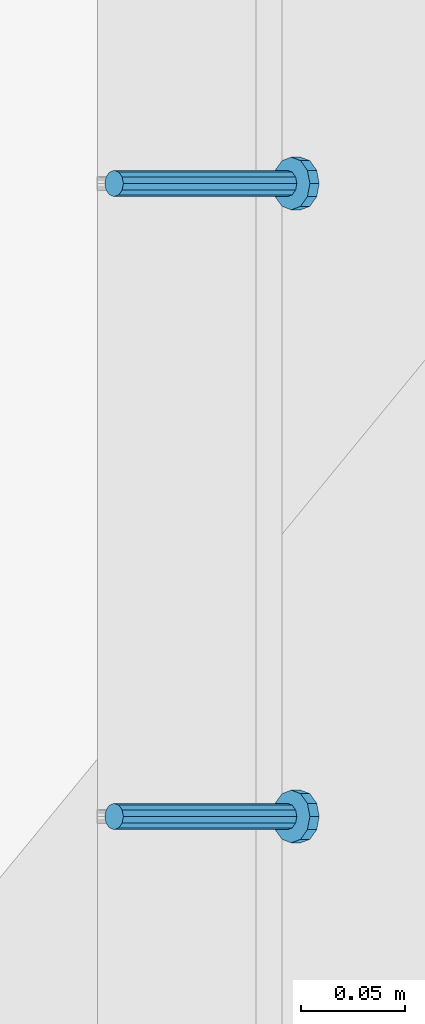
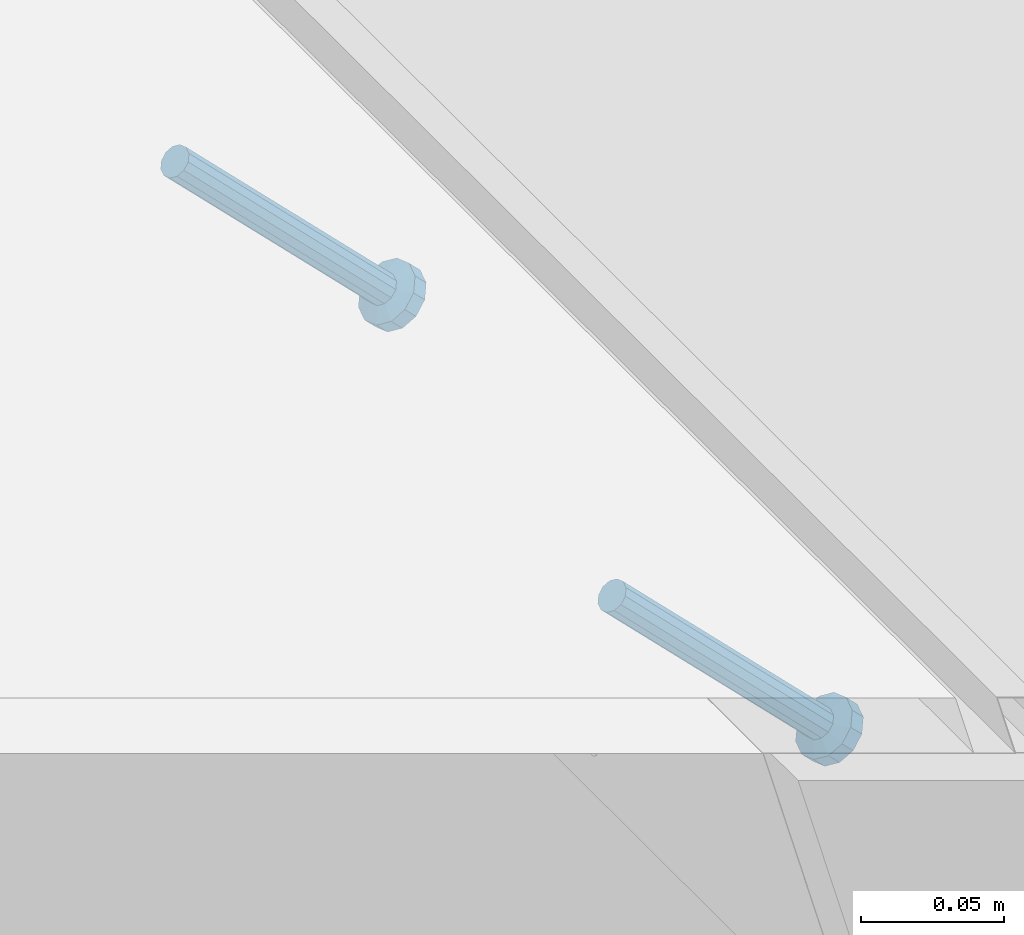
# One storey, part 2409 of 3843: 2 members, 1 element without a shape of its own.
"""IFC2X3 building model written with IfcOpenShell, lengths in millimetres."""

import ifcopenshell
import ifcopenshell.guid

model = None  # the IFC model being written
_history = None  # IfcOwnerHistory: only IFC2X3 demands one
_inside = {}  # id of a spatial element -> (the spatial element, [elements in it])
_under = {}  # id of a project, library or spatial element -> (it, [spatial elements below it])
_declared = {}  # id of a project -> (the project, [libraries it declares])
_typed = {}  # id of a type object -> (the type object, [elements of that type])
_made_of = {}  # id of a material, layer set ... -> (it, [elements and type objects made of it])


def new_model(schema):
    """Start an empty IFC model of exactly this schema.

    Asked for "IFC4X3", IfcOpenShell would pick the latest addendum, in which some entities
    have other attributes; the version numbers below select the first issue.
    IFC2X3 requires an IfcOwnerHistory on every rooted entity: one is made here for all.
    """
    global model, _history
    if schema == "IFC4X3":
        model = ifcopenshell.file(schema_version=(4, 3, 0, 0))
    else:
        model = ifcopenshell.file(schema=schema)
    _inside.clear()
    _under.clear()
    _declared.clear()
    _typed.clear()
    _made_of.clear()
    _history = None
    if model.schema == "IFC2X3":
        org = make("IfcOrganization", Name="unknown")
        user = make(
            "IfcPersonAndOrganization",
            ThePerson=make("IfcPerson", FamilyName="unknown"),
            TheOrganization=org,
        )
        app = make(
            "IfcApplication",
            ApplicationDeveloper=org,
            Version="unknown",
            ApplicationFullName="unknown",
            ApplicationIdentifier="unknown",
        )
        _history = make(
            "IfcOwnerHistory",
            OwningUser=user,
            OwningApplication=app,
            ChangeAction="ADDED",
            CreationDate=0,
        )
    return model


def make(cls, **values):
    """One entity of the class cls with the attributes given. An attribute that is None is left unset."""
    return model.create_entity(
        cls, **{name: value for name, value in values.items() if value is not None}
    )


def rooted(cls, **values):
    """An entity with a GlobalId (a new one), such as an element, a storey or a relation."""
    return make(cls, GlobalId=ifcopenshell.guid.new(), OwnerHistory=_history, **values)


def si_unit(unit_type, name, prefix=None):
    """IfcSIUnit, for example si_unit("LENGTHUNIT", "METRE", prefix="MILLI")."""
    return make("IfcSIUnit", UnitType=unit_type, Prefix=prefix, Name=name)


def assignment(units):
    """IfcUnitAssignment: the units of a project."""
    return None if units is None else make("IfcUnitAssignment", Units=units)


def point(xyz):
    """IfcCartesianPoint."""
    return None if xyz is None else make("IfcCartesianPoint", Coordinates=xyz)


def direction(xyz):
    """IfcDirection."""
    return None if xyz is None else make("IfcDirection", DirectionRatios=xyz)


def frame(location, z_axis=None, x_axis=None):
    """IfcAxis2Placement3D, a coordinate frame: its origin and axes. An axis left out is left unset."""
    return make(
        "IfcAxis2Placement3D",
        Location=point(location),
        Axis=direction(z_axis),
        RefDirection=direction(x_axis),
    )


def origin_with_axes():
    """The frame at (0, 0, 0) with the z axis (0, 0, 1) and the x axis (1, 0, 0) written out."""
    return frame((0.0, 0.0, 0.0), z_axis=(0.0, 0.0, 1.0), x_axis=(1.0, 0.0, 0.0))


def place(relative_to, where):
    """IfcLocalPlacement: puts the frame where relative to a parent placement (None: the world)."""
    return make(
        "IfcLocalPlacement", PlacementRelTo=relative_to, RelativePlacement=where
    )


def context(
    kind, dimensions, precision=None, world=None, true_north=None, identifier=None
):
    """IfcGeometricRepresentationContext, for example the 3D "Model" context."""
    return make(
        "IfcGeometricRepresentationContext",
        ContextIdentifier=identifier,
        ContextType=kind,
        CoordinateSpaceDimension=dimensions,
        Precision=precision,
        WorldCoordinateSystem=world,
        TrueNorth=true_north,
    )


def subcontext(parent, identifier, kind, view, scale=None):
    """IfcGeometricRepresentationSubContext, for example "Body" below "Model"."""
    return make(
        "IfcGeometricRepresentationSubContext",
        ContextIdentifier=identifier,
        ContextType=kind,
        ParentContext=parent,
        TargetScale=scale,
        TargetView=view,
    )


def project(units=None, contexts=None):
    """IfcProject with its units and contexts."""
    return rooted(
        "IfcProject",
        Name="project",
        RepresentationContexts=contexts,
        UnitsInContext=assignment(units),
    )


def spatial(cls, under=None, at=None, **own):
    """A site, building, storey or space (cls), placed at a placement, below another one or the project."""
    s = rooted(cls, ObjectPlacement=at, **own)
    if under is not None:
        _under.setdefault(under.id(), (under, []))[1].append(s)
    return s


def faces_of(points, faces, orient=None, outer=None):
    """IfcFace entities. A face is a list of loops; a loop is a list of indices into points, from 0.

    orient and outer hold one flag for each loop. By default every Orientation is true, the
    first loop of a face is its IfcFaceOuterBound and the others are IfcFaceBound.
    """
    made = []
    for i, loops in enumerate(faces):
        bounds = []
        for j, loop in enumerate(loops):
            is_outer = j == 0 if outer is None else outer[i][j]
            bounds.append(
                make(
                    "IfcFaceOuterBound" if is_outer else "IfcFaceBound",
                    Bound=make("IfcPolyLoop", Polygon=[points[k] for k in loop]),
                    Orientation=True if orient is None else orient[i][j],
                )
            )
        made.append(make("IfcFace", Bounds=bounds))
    return made


def faceted_brep(points, faces, orient=None, outer=None, voids=None):
    """IfcFacetedBrep: a solid bounded by flat faces; with voids (closed shells), ...WithVoids."""
    shared = [point(p) for p in points]
    hull = make("IfcClosedShell", CfsFaces=faces_of(shared, faces, orient, outer))
    if voids is None:
        return make("IfcFacetedBrep", Outer=hull)
    return make(
        "IfcFacetedBrepWithVoids",
        Outer=hull,
        Voids=[
            make(cls, CfsFaces=faces_of(shared, fs, o, b)) for cls, fs, o, b in voids
        ],
    )


def shape(context_of_items, identifier, shape_type, items):
    """IfcShapeRepresentation: the items that make up one representation, for example the "Body"."""
    return make(
        "IfcShapeRepresentation",
        ContextOfItems=context_of_items,
        RepresentationIdentifier=identifier,
        RepresentationType=shape_type,
        Items=items,
    )


def material(Name=None, Category=None):
    """IfcMaterial."""
    return make("IfcMaterial", Name=Name, Category=Category)


def made_of(thing, what):
    """Note that an element or type object is made of a material, layer set ...; save() writes the relation."""
    if what is not None:
        _made_of.setdefault(what.id(), (what, []))[1].append(thing)
    return thing


def type_object(cls, material=None, **own):
    """A type object (cls), such as IfcWallType, which elements share."""
    return made_of(rooted(cls, **own), material)


def element(
    cls,
    number,
    at=None,
    inside=None,
    cuts=None,
    type_object=None,
    material=None,
    context=None,
    identifier="Body",
    shape_type=None,
    held_by="IfcProductDefinitionShape",
    body=None,
    shapes=None,
    **own,
):
    """One element of the class cls, such as IfcWall. Its Tag is "e" and its number.

    at: its placement. inside: the storey or other place that contains it. cuts: it is an
    opening in that element (IfcRelVoidsElement). A single representation is given by context,
    identifier, shape_type and body (its items); several are given by shapes. held_by: the class
    of the entity that holds the representations. save() writes the other relations.
    """
    e = rooted(cls, Tag="e%d" % number, ObjectPlacement=at, **own)
    if body is not None:
        shapes = [shape(context, identifier, shape_type, body)]
    if shapes is not None:
        e.Representation = make(held_by, Representations=shapes)
    if inside is not None:
        _inside.setdefault(inside.id(), (inside, []))[1].append(e)
    if cuts is not None:
        rooted(
            "IfcRelVoidsElement", RelatingBuildingElement=cuts, RelatedOpeningElement=e
        )
    if type_object is not None:
        _typed.setdefault(type_object.id(), (type_object, []))[1].append(e)
    return made_of(e, material)


def aggregate(whole, parts):
    """IfcRelAggregates: a whole, such as a stair, and the parts it consists of."""
    return rooted("IfcRelAggregates", RelatingObject=whole, RelatedObjects=parts)


def save(model, path):
    """Write the relations noted so far, then the file.

    IfcRelAggregates (storeys below a building ...), IfcRelContainedInSpatialStructure (elements
    in a storey), IfcRelDefinesByType, IfcRelAssociatesMaterial and IfcRelDeclares: one each for
    every whole, place, type object, material and project.
    """
    for whole, parts in _under.values():
        aggregate(whole, parts)
    for where, things in _inside.values():
        rooted(
            "IfcRelContainedInSpatialStructure",
            RelatedElements=things,
            RelatingStructure=where,
        )
    for kind, things in _typed.values():
        rooted("IfcRelDefinesByType", RelatedObjects=things, RelatingType=kind)
    for what, things in _made_of.values():
        rooted("IfcRelAssociatesMaterial", RelatedObjects=things, RelatingMaterial=what)
    for by, libraries in _declared.values():
        rooted("IfcRelDeclares", RelatingContext=by, RelatedDefinitions=libraries)
    model.write(path)


model = new_model("IFC2X3")

# Units and contexts
model_context = context("Model", 3, precision=1e-05, world=origin_with_axes())
body_context = subcontext(model_context, "Body", "Model", "MODEL_VIEW")
ifc_project = project(units=[si_unit("LENGTHUNIT", "METRE", prefix="MILLI"), si_unit("AREAUNIT", "SQUARE_METRE"), si_unit("VOLUMEUNIT", "CUBIC_METRE"), si_unit("MASSUNIT", "GRAM", prefix="KILO"), si_unit("TIMEUNIT", "SECOND"), si_unit("PLANEANGLEUNIT", "RADIAN"), si_unit("SOLIDANGLEUNIT", "STERADIAN"), si_unit("THERMODYNAMICTEMPERATUREUNIT", "DEGREE_CELSIUS"), si_unit("LUMINOUSINTENSITYUNIT", "LUMEN")], contexts=[model_context])

# Site, building, storey
site_placement = place(None, origin_with_axes())
site = spatial("IfcSite", under=ifc_project, at=site_placement, CompositionType="ELEMENT")
building_placement = place(site_placement, origin_with_axes())
building = spatial("IfcBuilding", under=site, at=building_placement, Name="Undefined", CompositionType="ELEMENT")
storey_placement = place(building_placement, origin_with_axes())
storey = spatial("IfcBuildingStorey", under=building, at=storey_placement, Name="Undefined", CompositionType="ELEMENT", Elevation=0.0)

# Assembly, members
assembly_placement = place(storey_placement, origin_with_axes())
assembly = element("IfcElementAssembly", 1, at=assembly_placement, inside=storey, Name="EMBED_ANGLE", AssemblyPlace="NOTDEFINED", PredefinedType="RIGID_FRAME")
ifc_material = material(Name="STEEL/A108")
member_type = type_object("IfcMemberType", PredefinedType="NOTDEFINED")
member_1_placement = place(assembly_placement, frame((44851.3834999999, 87328.375189209, 30456.1875), z_axis=(0.0, 1.0, 0.0), x_axis=(0.707106781186548, 0.0, -0.707106781186548)))
member_1 = element("IfcMember", 2, at=member_1_placement, type_object=member_type, material=ifc_material, Name="HEADED STUD ANCHOR", context=body_context, shape_type="Brep", body=[
    faceted_brep([(7.27595761418343e-12, -3.18000006675175, 5.5), (0.0, -5.49999999998363, 3.1800000667572), (118.110000000976, -5.49999999999091, 3.1800000667572), (118.110000000983, -3.18000006675175, 5.5), (0.0, -6.3499999046162, 0.0), (118.110000000968, -6.34999990461256, 0.0), (0.0, -5.49999999998363, -3.1800000667572), (118.110000000976, -5.49999999999091, -3.1800000667572), (7.27595761418343e-12, -3.18000006675175, -5.5), (118.110000000983, -3.18000006675175, -5.5), (7.27595761418343e-12, -1.81898940354586e-12, -6.34999990463257), (118.110000000968, -1.81898940354586e-12, -6.34999990463257), (0.0, 3.18000006675175, -5.5), (118.110000000968, 3.18000006674811, -5.5), (7.27595761418343e-12, 5.49999999998363, -3.1800000667572), (118.110000000983, 5.49999999998363, -3.1800000667572), (7.27595761418343e-12, 6.3499999046162, 0.0), (118.110000000976, 6.34999990461256, 0.0), (7.27595761418343e-12, 5.49999999998363, 3.1800000667572), (118.110000000983, 5.49999999998363, 3.1800000667572), (0.0, 3.18000006675175, 5.5), (118.110000000968, 3.18000006674811, 5.5), (7.27595761418343e-12, -1.81898940354586e-12, 6.34999990463257), (118.110000000968, -1.81898940354586e-12, 6.34999990463257), (120.650000000991, -10.9899997710909, 6.34999990463257), (120.650000000998, -6.34000015257152, 10.9899997711182), (120.650000000991, -12.6999998092379, 0.0), (120.650000000991, -10.9899997710909, -6.34999990463257), (120.650000000998, -6.34000015257152, -10.9899997711182), (120.650000000991, -1.81898940354586e-12, -12.6899995803833), (120.650000000991, 6.34000015257152, -10.9899997711182), (120.650000000998, 10.9899997710909, -6.34999990463257), (120.650000000991, 12.6999998092342, 0.0), (120.650000000998, 10.9899997710909, 6.34999990463257), (120.650000000991, 6.34000015257152, 10.9899997711182), (120.650000000991, -1.81898940354586e-12, 12.6899995803833), (127.000000001048, -10.9899997710945, 6.34999990463257), (127.000000001048, -6.34000015257152, 10.9899997711182), (127.000000001048, -12.6999998092342, 0.0), (127.000000001048, -10.9899997710945, -6.34999990463257), (127.000000001048, -6.34000015257152, -10.9899997711182), (127.000000001048, 1.81898940354586e-12, -12.6899995803833), (127.000000001048, 6.34000015256788, -10.9899997711182), (127.000000001048, 10.9899997710909, -6.34999990463257), (127.000000001048, 12.6999998092379, 0.0), (127.000000001048, 10.9899997710909, 6.34999990463257), (127.000000001048, 6.34000015256788, 10.9899997711182), (127.000000001048, 1.81898940354586e-12, 12.6899995803833)], [[[0, 1, 2, 3]], [[1, 4, 5, 2]], [[4, 6, 7, 5]], [[6, 8, 9, 7]], [[8, 10, 11, 9]], [[10, 12, 13, 11]], [[12, 14, 15, 13]], [[14, 16, 17, 15]], [[16, 18, 19, 17]], [[18, 20, 21, 19]], [[20, 22, 23, 21]], [[22, 0, 3, 23]], [[22, 20, 18, 16, 14, 12, 10, 8, 6, 4, 1, 0]], [[3, 2, 24, 25]], [[2, 5, 26, 24]], [[5, 7, 27, 26]], [[7, 9, 28, 27]], [[9, 11, 29, 28]], [[11, 13, 30, 29]], [[13, 15, 31, 30]], [[15, 17, 32, 31]], [[17, 19, 33, 32]], [[19, 21, 34, 33]], [[21, 23, 35, 34]], [[23, 3, 25, 35]], [[25, 24, 36, 37]], [[24, 26, 38, 36]], [[26, 27, 39, 38]], [[27, 28, 40, 39]], [[28, 29, 41, 40]], [[29, 30, 42, 41]], [[30, 31, 43, 42]], [[31, 32, 44, 43]], [[32, 33, 45, 44]], [[33, 34, 46, 45]], [[34, 35, 47, 46]], [[35, 25, 37, 47]], [[38, 39, 40, 41, 42, 43, 44, 45, 46, 47, 37, 36]]]),
])
member_2_placement = place(assembly_placement, frame((44851.3834999999, 87633.175189209, 30456.1875), z_axis=(0.0, 1.0, 0.0), x_axis=(0.707106781186548, 0.0, -0.707106781186548)))
member_2 = element("IfcMember", 3, at=member_2_placement, type_object=member_type, material=ifc_material, Name="HEADED STUD ANCHOR", context=body_context, shape_type="Brep", body=[
    faceted_brep([(7.27595761418343e-12, -3.18000006675175, 5.5), (0.0, -5.49999999998363, 3.1800000667572), (118.110000000976, -5.49999999999091, 3.1800000667572), (118.110000000983, -3.18000006675175, 5.5), (0.0, -6.3499999046162, 0.0), (118.110000000968, -6.34999990461256, 0.0), (0.0, -5.49999999998363, -3.1800000667572), (118.110000000976, -5.49999999999091, -3.1800000667572), (7.27595761418343e-12, -3.18000006675175, -5.5), (118.110000000983, -3.18000006675175, -5.5), (7.27595761418343e-12, -1.81898940354586e-12, -6.34999990463257), (118.110000000968, -1.81898940354586e-12, -6.34999990463257), (0.0, 3.18000006675175, -5.5), (118.110000000968, 3.18000006674811, -5.5), (7.27595761418343e-12, 5.49999999998363, -3.1800000667572), (118.110000000983, 5.49999999998363, -3.1800000667572), (7.27595761418343e-12, 6.3499999046162, 0.0), (118.110000000976, 6.34999990461256, 0.0), (7.27595761418343e-12, 5.49999999998363, 3.1800000667572), (118.110000000983, 5.49999999998363, 3.1800000667572), (0.0, 3.18000006675175, 5.5), (118.110000000968, 3.18000006674811, 5.5), (7.27595761418343e-12, -1.81898940354586e-12, 6.34999990463257), (118.110000000968, -1.81898940354586e-12, 6.34999990463257), (120.650000000991, -10.9899997710909, 6.34999990463257), (120.650000000998, -6.34000015257152, 10.9899997711182), (120.650000000991, -12.6999998092379, 0.0), (120.650000000991, -10.9899997710909, -6.34999990463257), (120.650000000998, -6.34000015257152, -10.9899997711182), (120.650000000991, -1.81898940354586e-12, -12.6899995803833), (120.650000000991, 6.34000015257152, -10.9899997711182), (120.650000000998, 10.9899997710909, -6.34999990463257), (120.650000000991, 12.6999998092342, 0.0), (120.650000000998, 10.9899997710909, 6.34999990463257), (120.650000000991, 6.34000015257152, 10.9899997711182), (120.650000000991, -1.81898940354586e-12, 12.6899995803833), (127.000000001048, -10.9899997710945, 6.34999990463257), (127.000000001048, -6.34000015257152, 10.9899997711182), (127.000000001048, -12.6999998092342, 0.0), (127.000000001048, -10.9899997710945, -6.34999990463257), (127.000000001048, -6.34000015257152, -10.9899997711182), (127.000000001048, 1.81898940354586e-12, -12.6899995803833), (127.000000001048, 6.34000015256788, -10.9899997711182), (127.000000001048, 10.9899997710909, -6.34999990463257), (127.000000001048, 12.6999998092379, 0.0), (127.000000001048, 10.9899997710909, 6.34999990463257), (127.000000001048, 6.34000015256788, 10.9899997711182), (127.000000001048, 1.81898940354586e-12, 12.6899995803833)], [[[0, 1, 2, 3]], [[1, 4, 5, 2]], [[4, 6, 7, 5]], [[6, 8, 9, 7]], [[8, 10, 11, 9]], [[10, 12, 13, 11]], [[12, 14, 15, 13]], [[14, 16, 17, 15]], [[16, 18, 19, 17]], [[18, 20, 21, 19]], [[20, 22, 23, 21]], [[22, 0, 3, 23]], [[22, 20, 18, 16, 14, 12, 10, 8, 6, 4, 1, 0]], [[3, 2, 24, 25]], [[2, 5, 26, 24]], [[5, 7, 27, 26]], [[7, 9, 28, 27]], [[9, 11, 29, 28]], [[11, 13, 30, 29]], [[13, 15, 31, 30]], [[15, 17, 32, 31]], [[17, 19, 33, 32]], [[19, 21, 34, 33]], [[21, 23, 35, 34]], [[23, 3, 25, 35]], [[25, 24, 36, 37]], [[24, 26, 38, 36]], [[26, 27, 39, 38]], [[27, 28, 40, 39]], [[28, 29, 41, 40]], [[29, 30, 42, 41]], [[30, 31, 43, 42]], [[31, 32, 44, 43]], [[32, 33, 45, 44]], [[33, 34, 46, 45]], [[34, 35, 47, 46]], [[35, 25, 37, 47]], [[38, 39, 40, 41, 42, 43, 44, 45, 46, 47, 37, 36]]]),
])
aggregate(assembly, [member_1, member_2])

save(model, "model.ifc")
